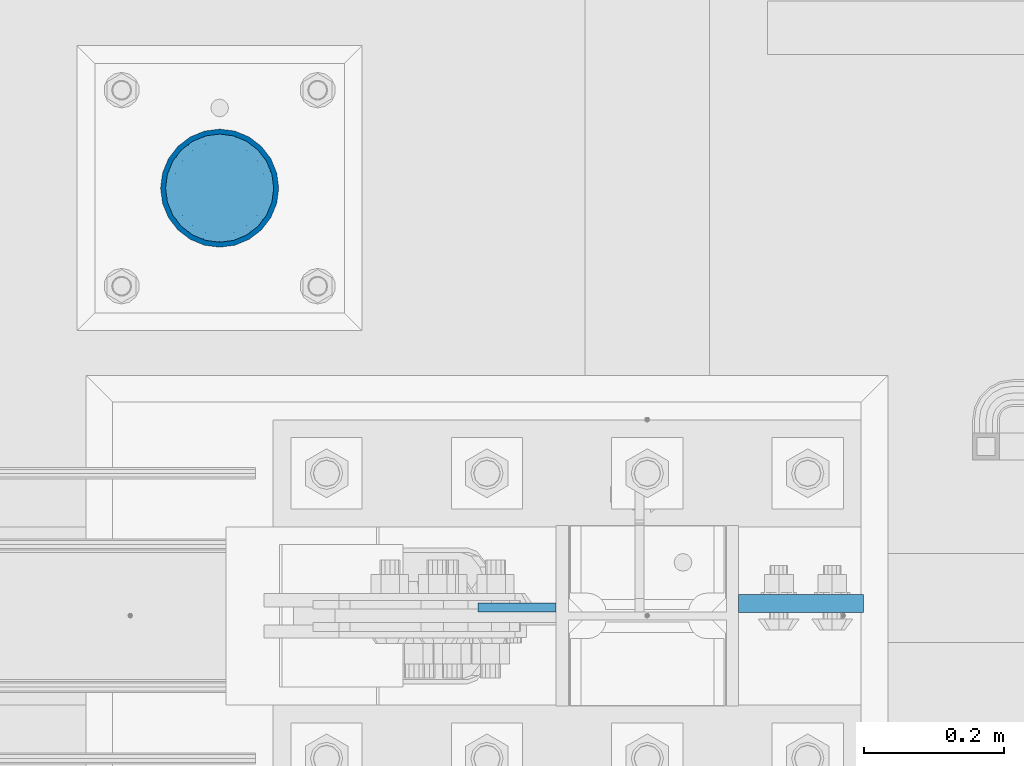
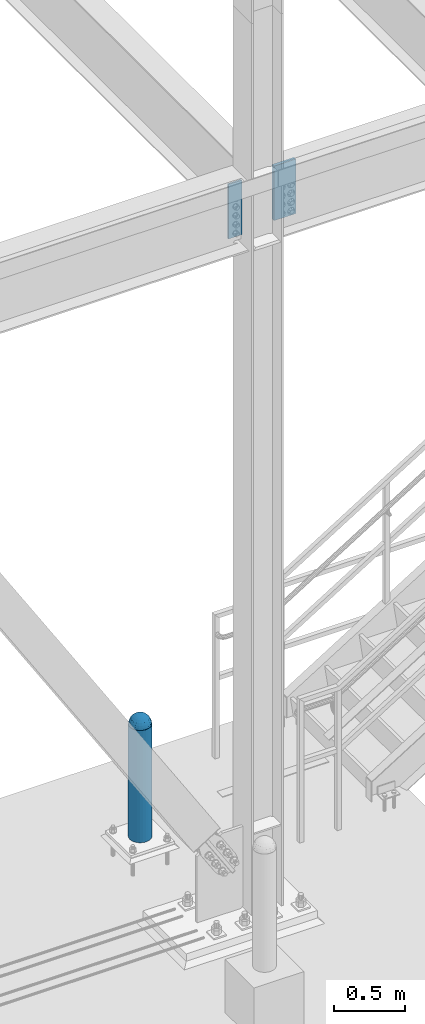
# One storey, part 1570 of 3843: 4 columns, 3 elements without a shape of their own.
"""IFC2X3 building model written with IfcOpenShell, lengths in millimetres."""

from ifc_helpers import new_model, si_unit, frame, origin_with_axes, place, context, subcontext, project, spatial, faceted_brep, material, type_object, element, aggregate, save


model = new_model("IFC2X3")

# Units and contexts
model_context = context("Model", 3, precision=1e-05, world=origin_with_axes())
body_context = subcontext(model_context, "Body", "Model", "MODEL_VIEW")
ifc_project = project(units=[si_unit("LENGTHUNIT", "METRE", prefix="MILLI"), si_unit("AREAUNIT", "SQUARE_METRE"), si_unit("VOLUMEUNIT", "CUBIC_METRE"), si_unit("MASSUNIT", "GRAM", prefix="KILO"), si_unit("TIMEUNIT", "SECOND"), si_unit("PLANEANGLEUNIT", "RADIAN"), si_unit("SOLIDANGLEUNIT", "STERADIAN"), si_unit("THERMODYNAMICTEMPERATUREUNIT", "DEGREE_CELSIUS"), si_unit("LUMINOUSINTENSITYUNIT", "LUMEN")], contexts=[model_context])

# Site, building, storey
site_placement = place(None, origin_with_axes())
site = spatial("IfcSite", under=ifc_project, at=site_placement, CompositionType="ELEMENT")
building_placement = place(site_placement, origin_with_axes())
building = spatial("IfcBuilding", under=site, at=building_placement, Name="Undefined", CompositionType="ELEMENT")
storey_placement = place(building_placement, origin_with_axes())
storey = spatial("IfcBuildingStorey", under=building, at=storey_placement, Name="Undefined", CompositionType="ELEMENT", Elevation=0.0)

# Assembly, column
assembly_1_placement = place(storey_placement, origin_with_axes())
assembly_1 = element("IfcElementAssembly", 1, at=assembly_1_placement, inside=storey, Name="CONC. FILL", AssemblyPlace="NOTDEFINED", PredefinedType="REINFORCEMENT_UNIT")
ifc_material_1 = material(Name="CONCRETE/1500")
column_type_1 = type_object("IfcColumnType", PredefinedType="NOTDEFINED")
column_1_placement = place(assembly_1_placement, frame((29870.4, 89725.5, 31411.8625), z_axis=(-1.0, 0.0, 0.0), x_axis=(0.0, 0.0, 1.0)))
column_1 = element("IfcColumn", 2, at=column_1_placement, type_object=column_type_1, material=ifc_material_1, Name="CONC. FILL", context=body_context, shape_type="Brep", body=[
    faceted_brep([(0.0, 0.0, 2.0), (0.0, -0.619999999995343, 1.89999999999964), (3.36549999999988, -7.1422259999963, 21.9814139999999), (3.36549999999988, 0.0, 23.1139999999996), (0.0, -1.17999999999302, 1.6200000000008), (3.36549999999988, -13.5910319999966, 18.6992260000006), (0.0, -1.61999999999534, 1.18000000000029), (3.36549999999988, -18.699225999997, 13.5910320000003), (0.0, -1.89999999999418, 0.6200000000008), (3.36549999999988, -21.9814139999944, 7.14222599999994), (0.0, -2.0, 0.0), (3.36549999999988, -23.1140000000014, 0.0), (0.0, -1.89999999999418, -0.6200000000008), (3.36549999999988, -21.9814139999944, -7.14222599999994), (0.0, -1.61999999999534, -1.18000000000029), (3.36549999999988, -18.699225999997, -13.5910320000003), (0.0, -1.17999999999302, -1.6200000000008), (3.36549999999988, -13.5910319999966, -18.6992260000006), (0.0, -0.619999999995343, -1.89999999999964), (3.36549999999988, -7.1422259999963, -21.9814139999999), (0.0, 0.0, -2.0), (3.36549999999988, 0.0, -23.1139999999996), (0.0, 0.619999999995343, -1.89999999999964), (3.36549999999988, 7.1422259999963, -21.9814139999999), (0.0, 1.17999999999302, -1.6200000000008), (3.36549999999988, 13.5910319999966, -18.6992260000006), (0.0, 1.61999999999534, -1.18000000000029), (3.36549999999988, 18.699225999997, -13.5910320000003), (0.0, 1.89999999999418, -0.6200000000008), (3.36549999999988, 21.9814139999944, -7.14222599999994), (0.0, 2.0, 0.0), (3.36549999999988, 23.1140000000014, 0.0), (0.0, 1.89999999999418, 0.6200000000008), (3.36549999999988, 21.9814139999944, 7.14222599999994), (0.0, 1.61999999999534, 1.18000000000029), (3.36549999999988, 18.699225999997, 13.5910320000003), (0.0, 1.17999999999302, 1.6200000000008), (3.36549999999988, 13.5910319999966, 18.6992260000006), (0.0, 0.619999999995343, 1.89999999999964), (3.36549999999988, 7.1422259999963, 21.9814139999999), (8.41374999999971, -11.1214661999984, 34.2282018000005), (8.41374999999971, 0.0, 35.9917999999998), (8.41374999999971, -21.1631784000056, 29.1173662000001), (8.41374999999971, -29.1173661999928, 21.1631784000001), (8.41374999999971, -34.2282017999969, 11.1214662000002), (8.41374999999971, -35.9918000000034, 0.0), (8.41374999999971, -34.2282017999969, -11.1214662000002), (8.41374999999971, -29.1173661999928, -21.1631784000001), (8.41374999999971, -21.1631784000056, -29.1173662000001), (8.41374999999971, -11.1214661999984, -34.2282018000005), (8.41374999999971, 0.0, -35.9917999999998), (8.41374999999971, 11.1214661999984, -34.2282018000005), (8.41374999999971, 21.1631784000056, -29.1173662000001), (8.41374999999971, 29.1173661999928, -21.1631784000001), (8.41374999999971, 34.2282017999969, -11.1214662000002), (8.41374999999971, 35.9918000000034, 0.0), (8.41374999999971, 34.2282017999969, 11.1214662000002), (8.41374999999971, 29.1173661999928, 21.1631784000001), (8.41374999999971, 21.1631784000056, 29.1173662000001), (8.41374999999971, 11.1214661999984, 34.2282018000005), (16.8274999999994, -15.3047700000025, 47.1030300000002), (16.8274999999994, 0.0, 49.5300000000007), (16.8274999999994, -29.1236400000053, 40.0697700000001), (16.8274999999994, -40.0697700000019, 29.1236399999998), (16.8274999999994, -47.1030299999984, 15.3047700000006), (16.8274999999994, -49.5299999999988, 0.0), (16.8274999999994, -47.1030299999984, -15.3047700000006), (16.8274999999994, -40.0697700000019, -29.1236399999998), (16.8274999999994, -29.1236400000053, -40.0697700000001), (16.8274999999994, -15.3047700000025, -47.1030300000002), (16.8274999999994, 0.0, -49.5300000000007), (16.8274999999994, 15.3047700000025, -47.1030300000002), (16.8274999999994, 29.1236400000053, -40.0697700000001), (16.8274999999994, 40.0697700000019, -29.1236399999998), (16.8274999999994, 47.1030299999984, -15.3047700000006), (16.8274999999994, 49.5299999999988, 0.0), (16.8274999999994, 47.1030299999984, 15.3047700000006), (16.8274999999994, 40.0697700000019, 29.1236399999998), (16.8274999999994, 29.1236400000053, 40.0697700000001), (16.8274999999994, 15.3047700000025, 47.1030300000002), (33.6549999999988, -20.4063599999936, 62.8040400000009), (33.6549999999988, 0.0, 66.0400000000009), (33.6549999999988, -38.831520000007, 53.4263599999995), (33.6549999999988, -53.4263599999977, 38.8315199999997), (33.6549999999988, -62.8040400000027, 20.4063600000009), (33.6549999999988, -66.0399999999936, 0.0), (33.6549999999988, -62.8040400000027, -20.4063600000009), (33.6549999999988, -53.4263599999977, -38.8315199999997), (33.6549999999988, -38.831520000007, -53.4263599999995), (33.6549999999988, -20.4063599999936, -62.8040400000009), (33.6549999999988, 0.0, -66.0400000000009), (33.6549999999988, 20.4063599999936, -62.8040400000009), (33.6549999999988, 38.831520000007, -53.4263599999995), (33.6549999999988, 53.4263599999977, -38.8315199999997), (33.6549999999988, 62.8040400000027, -20.4063600000009), (33.6549999999988, 66.0399999999936, 0.0), (33.6549999999988, 62.8040400000027, 20.4063600000009), (33.6549999999988, 53.4263599999977, 38.8315199999997), (33.6549999999988, 38.831520000007, 53.4263599999995), (33.6549999999988, 20.4063599999936, 62.8040400000009), (50.4824999999983, -23.3907901500061, 71.9891308499991), (50.4824999999983, 0.0, 75.6983500000006), (50.4824999999983, -44.5106298000028, 61.23996515), (50.4824999999983, -61.2399651500018, 44.5106297999992), (50.4824999999983, -71.9891308499937, 23.3907901500006), (50.4824999999983, -75.698350000006, 0.0), (50.4824999999983, -71.9891308499937, -23.3907901500006), (50.4824999999983, -61.2399651500018, -44.5106297999992), (50.4824999999983, -44.5106298000028, -61.23996515), (50.4824999999983, -23.3907901500061, -71.9891308499991), (50.4824999999983, 0.0, -75.6983500000006), (50.4824999999983, 23.3907901500061, -71.9891308499991), (50.4824999999983, 44.5106298000028, -61.23996515), (50.4824999999983, 61.2399651500018, -44.5106297999992), (50.4824999999983, 71.9891308499937, -23.3907901500006), (50.4824999999983, 75.698350000006, 0.0), (50.4824999999983, 71.9891308499937, 23.3907901500006), (50.4824999999983, 61.2399651500018, 44.5106297999992), (50.4824999999983, 44.5106298000028, 61.23996515), (50.4824999999983, 23.3907901500061, 71.9891308499991), (67.3099999999977, -24.9977910000016, 76.9349490000004), (67.3099999999977, 0.0, 80.8989999999994), (67.3099999999977, -47.5686120000028, 65.4472910000004), (67.3099999999977, -65.447291000004, 47.5686119999991), (67.3099999999977, -76.9349490000022, 24.9977909999998), (67.3099999999977, -80.8990000000049, 0.0), (67.3099999999977, -76.9349490000022, -24.9977909999998), (67.3099999999977, -65.447291000004, -47.5686119999991), (67.3099999999977, -47.5686120000028, -65.4472910000004), (67.3099999999977, -24.9977910000016, -76.9349490000004), (67.3099999999977, 0.0, -80.8989999999994), (67.3099999999977, 24.9977910000016, -76.9349490000004), (67.3099999999977, 47.5686120000028, -65.4472910000004), (67.3099999999977, 65.447291000004, -47.5686119999991), (67.3099999999977, 76.9349490000022, -24.9977909999998), (67.3099999999977, 80.8990000000049, 0.0), (67.3099999999977, 76.9349490000022, 24.9977909999998), (67.3099999999977, 65.447291000004, 47.5686119999991), (67.3099999999977, 47.5686120000028, 65.4472910000004), (67.3099999999977, 24.9977910000016, 76.9349490000004), (84.1374999999935, -25.5079499999993, 78.5050499999998), (84.1374999999935, 0.0, 82.5499999999993), (84.1374999999935, -48.5393999999942, 66.7829500000007), (84.1374999999935, -66.7829499999934, 48.5393999999997), (84.1374999999935, -78.505050000007, 25.5079499999993), (84.1374999999935, -82.5500000000029, 0.0), (84.1374999999935, -78.505050000007, -25.5079499999993), (84.1374999999935, -66.7829499999934, -48.5393999999997), (84.1374999999935, -48.5393999999942, -66.7829500000007), (84.1374999999935, -25.5079499999993, -78.5050499999998), (84.1374999999935, 0.0, -82.5499999999993), (84.1374999999935, 25.5079499999993, -78.5050499999998), (84.1374999999935, 48.5393999999942, -66.7829500000007), (84.1374999999935, 66.7829499999934, -48.5393999999997), (84.1374999999935, 78.505050000007, -25.5079499999993), (84.1374999999935, 82.5500000000029, 0.0), (84.1374999999935, 78.505050000007, 25.5079499999993), (84.1374999999935, 66.7829499999934, 48.5393999999997), (84.1374999999935, 48.5393999999942, 66.7829500000007), (84.1374999999935, 25.5079499999993, 78.5050499999998), (100.964999999993, -24.9977910000016, 76.9349490000004), (100.964999999993, 0.0, 80.8989999999994), (100.964999999993, -47.5686120000028, 65.4472910000004), (100.964999999993, -65.447291000004, 47.5686119999991), (100.964999999993, -76.9349490000022, 24.9977909999998), (100.964999999993, -80.8990000000049, 0.0), (100.964999999993, -76.9349490000022, -24.9977909999998), (100.964999999993, -65.447291000004, -47.5686119999991), (100.964999999993, -47.5686120000028, -65.4472910000004), (100.964999999993, -24.9977910000016, -76.9349490000004), (100.964999999993, 0.0, -80.8989999999994), (100.964999999993, 24.9977910000016, -76.9349490000004), (100.964999999993, 47.5686120000028, -65.4472910000004), (100.964999999993, 65.447291000004, -47.5686119999991), (100.964999999993, 76.9349490000022, -24.9977909999998), (100.964999999993, 80.8990000000049, 0.0), (100.964999999993, 76.9349490000022, 24.9977909999998), (100.964999999993, 65.447291000004, 47.5686119999991), (100.964999999993, 47.5686120000028, 65.4472910000004), (100.964999999993, 24.9977910000016, 76.9349490000004), (117.792499999992, -23.3907901500061, 71.9891308499991), (117.792499999992, 0.0, 75.6983500000006), (117.792499999992, -44.5106298000028, 61.23996515), (117.792499999992, -61.2399651500018, 44.5106297999992), (117.792499999992, -71.9891308499937, 23.3907901500006), (117.792499999992, -75.698350000006, 0.0), (117.792499999992, -71.9891308499937, -23.3907901500006), (117.792499999992, -61.2399651500018, -44.5106297999992), (117.792499999992, -44.5106298000028, -61.23996515), (117.792499999992, -23.3907901500061, -71.9891308499991), (117.792499999992, 0.0, -75.6983500000006), (117.792499999992, 23.3907901500061, -71.9891308499991), (117.792499999992, 44.5106298000028, -61.23996515), (117.792499999992, 61.2399651500018, -44.5106297999992), (117.792499999992, 71.9891308499937, -23.3907901500006), (117.792499999992, 75.698350000006, 0.0), (117.792499999992, 71.9891308499937, 23.3907901500006), (117.792499999992, 61.2399651500018, 44.5106297999992), (117.792499999992, 44.5106298000028, 61.23996515), (117.792499999992, 23.3907901500061, 71.9891308499991), (134.619999999992, -20.4063599999936, 62.8040400000009), (134.619999999992, 0.0, 66.0400000000009), (134.619999999992, -38.831520000007, 53.4263599999995), (134.619999999992, -53.4263599999977, 38.8315199999997), (134.619999999992, -62.8040400000027, 20.4063600000009), (134.619999999992, -66.0399999999936, 0.0), (134.619999999992, -62.8040400000027, -20.4063600000009), (134.619999999992, -53.4263599999977, -38.8315199999997), (134.619999999992, -38.831520000007, -53.4263599999995), (134.619999999992, -20.4063599999936, -62.8040400000009), (134.619999999992, 0.0, -66.0400000000009), (134.619999999992, 20.4063599999936, -62.8040400000009), (134.619999999992, 38.831520000007, -53.4263599999995), (134.619999999992, 53.4263599999977, -38.8315199999997), (134.619999999992, 62.8040400000027, -20.4063600000009), (134.619999999992, 66.0399999999936, 0.0), (134.619999999992, 62.8040400000027, 20.4063600000009), (134.619999999992, 53.4263599999977, 38.8315199999997), (134.619999999992, 38.831520000007, 53.4263599999995), (134.619999999992, 20.4063599999936, 62.8040400000009), (151.447499999991, -15.3047700000025, 47.1030300000002), (151.447499999991, 0.0, 49.5300000000007), (151.447499999991, -29.1236400000053, 40.0697700000001), (151.447499999991, -40.0697700000019, 29.1236399999998), (151.447499999991, -47.1030299999984, 15.3047700000006), (151.447499999991, -49.5299999999988, 0.0), (151.447499999991, -47.1030299999984, -15.3047700000006), (151.447499999991, -40.0697700000019, -29.1236399999998), (151.447499999991, -29.1236400000053, -40.0697700000001), (151.447499999991, -15.3047700000025, -47.1030300000002), (151.447499999991, 0.0, -49.5300000000007), (151.447499999991, 15.3047700000025, -47.1030300000002), (151.447499999991, 29.1236400000053, -40.0697700000001), (151.447499999991, 40.0697700000019, -29.1236399999998), (151.447499999991, 47.1030299999984, -15.3047700000006), (151.447499999991, 49.5299999999988, 0.0), (151.447499999991, 47.1030299999984, 15.3047700000006), (151.447499999991, 40.0697700000019, 29.1236399999998), (151.447499999991, 29.1236400000053, 40.0697700000001), (151.447499999991, 15.3047700000025, 47.1030300000002), (159.861249999991, -11.1214661999984, 34.2282018000005), (159.861249999991, 0.0, 35.9917999999998), (159.861249999991, -21.1631784000056, 29.1173662000001), (159.861249999991, -29.1173661999928, 21.1631784000001), (159.861249999991, -34.2282017999969, 11.1214662000002), (159.861249999991, -35.9918000000034, 0.0), (159.861249999991, -34.2282017999969, -11.1214662000002), (159.861249999991, -29.1173661999928, -21.1631784000001), (159.861249999991, -21.1631784000056, -29.1173662000001), (159.861249999991, -11.1214661999984, -34.2282018000005), (159.861249999991, 0.0, -35.9917999999998), (159.861249999991, 11.1214661999984, -34.2282018000005), (159.861249999991, 21.1631784000056, -29.1173662000001), (159.861249999991, 29.1173661999928, -21.1631784000001), (159.861249999991, 34.2282017999969, -11.1214662000002), (159.861249999991, 35.9918000000034, 0.0), (159.861249999991, 34.2282017999969, 11.1214662000002), (159.861249999991, 29.1173661999928, 21.1631784000001), (159.861249999991, 21.1631784000056, 29.1173662000001), (159.861249999991, 11.1214661999984, 34.2282018000005), (164.909499999991, -7.1422259999963, 21.9814139999999), (164.909499999991, 0.0, 23.1139999999996), (164.909499999991, -13.5910319999966, 18.6992260000006), (164.909499999991, -18.699225999997, 13.5910320000003), (164.909499999991, -21.9814139999944, 7.14222599999994), (164.909499999991, -23.1140000000014, 0.0), (164.909499999991, -21.9814139999944, -7.14222599999994), (164.909499999991, -18.699225999997, -13.5910320000003), (164.909499999991, -13.5910319999966, -18.6992260000006), (164.909499999991, -7.1422259999963, -21.9814139999999), (164.909499999991, 0.0, -23.1139999999996), (164.909499999991, 7.1422259999963, -21.9814139999999), (164.909499999991, 13.5910319999966, -18.6992260000006), (164.909499999991, 18.699225999997, -13.5910320000003), (164.909499999991, 21.9814139999944, -7.14222599999994), (164.909499999991, 23.1140000000014, 0.0), (164.909499999991, 21.9814139999944, 7.14222599999994), (164.909499999991, 18.699225999997, 13.5910320000003), (164.909499999991, 13.5910319999966, 18.6992260000006), (164.909499999991, 7.1422259999963, 21.9814139999999), (168.274999999991, -0.619999999995343, 1.89999999999964), (168.274999999991, 0.0, 2.0), (168.274999999991, -1.17999999999302, 1.6200000000008), (168.274999999991, -1.61999999999534, 1.18000000000029), (168.274999999991, -1.89999999999418, 0.6200000000008), (168.274999999991, -2.0, 0.0), (168.274999999991, -1.89999999999418, -0.6200000000008), (168.274999999991, -1.61999999999534, -1.18000000000029), (168.274999999991, -1.17999999999302, -1.6200000000008), (168.274999999991, -0.619999999995343, -1.89999999999964), (168.274999999991, 0.0, -2.0), (168.274999999991, 0.619999999995343, -1.89999999999964), (168.274999999991, 1.17999999999302, -1.6200000000008), (168.274999999991, 1.61999999999534, -1.18000000000029), (168.274999999991, 1.89999999999418, -0.6200000000008), (168.274999999991, 2.0, 0.0), (168.274999999991, 1.89999999999418, 0.6200000000008), (168.274999999991, 1.61999999999534, 1.18000000000029), (168.274999999991, 1.17999999999302, 1.6200000000008), (168.274999999991, 0.619999999995343, 1.89999999999964)], [[[0, 1, 2, 3]], [[1, 4, 5, 2]], [[4, 6, 7, 5]], [[6, 8, 9, 7]], [[8, 10, 11, 9]], [[10, 12, 13, 11]], [[12, 14, 15, 13]], [[14, 16, 17, 15]], [[16, 18, 19, 17]], [[18, 20, 21, 19]], [[20, 22, 23, 21]], [[22, 24, 25, 23]], [[24, 26, 27, 25]], [[26, 28, 29, 27]], [[28, 30, 31, 29]], [[30, 32, 33, 31]], [[32, 34, 35, 33]], [[34, 36, 37, 35]], [[36, 38, 39, 37]], [[38, 0, 3, 39]], [[38, 36, 34, 32, 30, 28, 26, 24, 22, 20, 18, 16, 14, 12, 10, 8, 6, 4, 1, 0]], [[3, 2, 40, 41]], [[2, 5, 42, 40]], [[5, 7, 43, 42]], [[7, 9, 44, 43]], [[9, 11, 45, 44]], [[11, 13, 46, 45]], [[13, 15, 47, 46]], [[15, 17, 48, 47]], [[17, 19, 49, 48]], [[19, 21, 50, 49]], [[21, 23, 51, 50]], [[23, 25, 52, 51]], [[25, 27, 53, 52]], [[27, 29, 54, 53]], [[29, 31, 55, 54]], [[31, 33, 56, 55]], [[33, 35, 57, 56]], [[35, 37, 58, 57]], [[37, 39, 59, 58]], [[39, 3, 41, 59]], [[41, 40, 60, 61]], [[40, 42, 62, 60]], [[42, 43, 63, 62]], [[43, 44, 64, 63]], [[44, 45, 65, 64]], [[45, 46, 66, 65]], [[46, 47, 67, 66]], [[47, 48, 68, 67]], [[48, 49, 69, 68]], [[49, 50, 70, 69]], [[50, 51, 71, 70]], [[51, 52, 72, 71]], [[52, 53, 73, 72]], [[53, 54, 74, 73]], [[54, 55, 75, 74]], [[55, 56, 76, 75]], [[56, 57, 77, 76]], [[57, 58, 78, 77]], [[58, 59, 79, 78]], [[59, 41, 61, 79]], [[61, 60, 80, 81]], [[60, 62, 82, 80]], [[62, 63, 83, 82]], [[63, 64, 84, 83]], [[64, 65, 85, 84]], [[65, 66, 86, 85]], [[66, 67, 87, 86]], [[67, 68, 88, 87]], [[68, 69, 89, 88]], [[69, 70, 90, 89]], [[70, 71, 91, 90]], [[71, 72, 92, 91]], [[72, 73, 93, 92]], [[73, 74, 94, 93]], [[74, 75, 95, 94]], [[75, 76, 96, 95]], [[76, 77, 97, 96]], [[77, 78, 98, 97]], [[78, 79, 99, 98]], [[79, 61, 81, 99]], [[81, 80, 100, 101]], [[80, 82, 102, 100]], [[82, 83, 103, 102]], [[83, 84, 104, 103]], [[84, 85, 105, 104]], [[85, 86, 106, 105]], [[86, 87, 107, 106]], [[87, 88, 108, 107]], [[88, 89, 109, 108]], [[89, 90, 110, 109]], [[90, 91, 111, 110]], [[91, 92, 112, 111]], [[92, 93, 113, 112]], [[93, 94, 114, 113]], [[94, 95, 115, 114]], [[95, 96, 116, 115]], [[96, 97, 117, 116]], [[97, 98, 118, 117]], [[98, 99, 119, 118]], [[99, 81, 101, 119]], [[101, 100, 120, 121]], [[100, 102, 122, 120]], [[102, 103, 123, 122]], [[103, 104, 124, 123]], [[104, 105, 125, 124]], [[105, 106, 126, 125]], [[106, 107, 127, 126]], [[107, 108, 128, 127]], [[108, 109, 129, 128]], [[109, 110, 130, 129]], [[110, 111, 131, 130]], [[111, 112, 132, 131]], [[112, 113, 133, 132]], [[113, 114, 134, 133]], [[114, 115, 135, 134]], [[115, 116, 136, 135]], [[116, 117, 137, 136]], [[117, 118, 138, 137]], [[118, 119, 139, 138]], [[119, 101, 121, 139]], [[121, 120, 140, 141]], [[120, 122, 142, 140]], [[122, 123, 143, 142]], [[123, 124, 144, 143]], [[124, 125, 145, 144]], [[125, 126, 146, 145]], [[126, 127, 147, 146]], [[127, 128, 148, 147]], [[128, 129, 149, 148]], [[129, 130, 150, 149]], [[130, 131, 151, 150]], [[131, 132, 152, 151]], [[132, 133, 153, 152]], [[133, 134, 154, 153]], [[134, 135, 155, 154]], [[135, 136, 156, 155]], [[136, 137, 157, 156]], [[137, 138, 158, 157]], [[138, 139, 159, 158]], [[139, 121, 141, 159]], [[141, 140, 160, 161]], [[140, 142, 162, 160]], [[142, 143, 163, 162]], [[143, 144, 164, 163]], [[144, 145, 165, 164]], [[145, 146, 166, 165]], [[146, 147, 167, 166]], [[147, 148, 168, 167]], [[148, 149, 169, 168]], [[149, 150, 170, 169]], [[150, 151, 171, 170]], [[151, 152, 172, 171]], [[152, 153, 173, 172]], [[153, 154, 174, 173]], [[154, 155, 175, 174]], [[155, 156, 176, 175]], [[156, 157, 177, 176]], [[157, 158, 178, 177]], [[158, 159, 179, 178]], [[159, 141, 161, 179]], [[161, 160, 180, 181]], [[160, 162, 182, 180]], [[162, 163, 183, 182]], [[163, 164, 184, 183]], [[164, 165, 185, 184]], [[165, 166, 186, 185]], [[166, 167, 187, 186]], [[167, 168, 188, 187]], [[168, 169, 189, 188]], [[169, 170, 190, 189]], [[170, 171, 191, 190]], [[171, 172, 192, 191]], [[172, 173, 193, 192]], [[173, 174, 194, 193]], [[174, 175, 195, 194]], [[175, 176, 196, 195]], [[176, 177, 197, 196]], [[177, 178, 198, 197]], [[178, 179, 199, 198]], [[179, 161, 181, 199]], [[181, 180, 200, 201]], [[180, 182, 202, 200]], [[182, 183, 203, 202]], [[183, 184, 204, 203]], [[184, 185, 205, 204]], [[185, 186, 206, 205]], [[186, 187, 207, 206]], [[187, 188, 208, 207]], [[188, 189, 209, 208]], [[189, 190, 210, 209]], [[190, 191, 211, 210]], [[191, 192, 212, 211]], [[192, 193, 213, 212]], [[193, 194, 214, 213]], [[194, 195, 215, 214]], [[195, 196, 216, 215]], [[196, 197, 217, 216]], [[197, 198, 218, 217]], [[198, 199, 219, 218]], [[199, 181, 201, 219]], [[201, 200, 220, 221]], [[200, 202, 222, 220]], [[202, 203, 223, 222]], [[203, 204, 224, 223]], [[204, 205, 225, 224]], [[205, 206, 226, 225]], [[206, 207, 227, 226]], [[207, 208, 228, 227]], [[208, 209, 229, 228]], [[209, 210, 230, 229]], [[210, 211, 231, 230]], [[211, 212, 232, 231]], [[212, 213, 233, 232]], [[213, 214, 234, 233]], [[214, 215, 235, 234]], [[215, 216, 236, 235]], [[216, 217, 237, 236]], [[217, 218, 238, 237]], [[218, 219, 239, 238]], [[219, 201, 221, 239]], [[221, 220, 240, 241]], [[220, 222, 242, 240]], [[222, 223, 243, 242]], [[223, 224, 244, 243]], [[224, 225, 245, 244]], [[225, 226, 246, 245]], [[226, 227, 247, 246]], [[227, 228, 248, 247]], [[228, 229, 249, 248]], [[229, 230, 250, 249]], [[230, 231, 251, 250]], [[231, 232, 252, 251]], [[232, 233, 253, 252]], [[233, 234, 254, 253]], [[234, 235, 255, 254]], [[235, 236, 256, 255]], [[236, 237, 257, 256]], [[237, 238, 258, 257]], [[238, 239, 259, 258]], [[239, 221, 241, 259]], [[241, 240, 260, 261]], [[240, 242, 262, 260]], [[242, 243, 263, 262]], [[243, 244, 264, 263]], [[244, 245, 265, 264]], [[245, 246, 266, 265]], [[246, 247, 267, 266]], [[247, 248, 268, 267]], [[248, 249, 269, 268]], [[249, 250, 270, 269]], [[250, 251, 271, 270]], [[251, 252, 272, 271]], [[252, 253, 273, 272]], [[253, 254, 274, 273]], [[254, 255, 275, 274]], [[255, 256, 276, 275]], [[256, 257, 277, 276]], [[257, 258, 278, 277]], [[258, 259, 279, 278]], [[259, 241, 261, 279]], [[261, 260, 280, 281]], [[260, 262, 282, 280]], [[262, 263, 283, 282]], [[263, 264, 284, 283]], [[264, 265, 285, 284]], [[265, 266, 286, 285]], [[266, 267, 287, 286]], [[267, 268, 288, 287]], [[268, 269, 289, 288]], [[269, 270, 290, 289]], [[270, 271, 291, 290]], [[271, 272, 292, 291]], [[272, 273, 293, 292]], [[273, 274, 294, 293]], [[274, 275, 295, 294]], [[275, 276, 296, 295]], [[276, 277, 297, 296]], [[277, 278, 298, 297]], [[278, 279, 299, 298]], [[279, 261, 281, 299]], [[282, 283, 284, 285, 286, 287, 288, 289, 290, 291, 292, 293, 294, 295, 296, 297, 298, 299, 281, 280]]]),
])
aggregate(assembly_1, [column_1])

assembly_2_placement = place(storey_placement, origin_with_axes())
assembly_2 = element("IfcElementAssembly", 3, at=assembly_2_placement, inside=storey, Name="PIPE_BOLLARD", AssemblyPlace="NOTDEFINED", PredefinedType="RIGID_FRAME")
ifc_material_2 = material()
column_type_2 = type_object("IfcColumnType", Name="PIPE6SCH40", PredefinedType="NOTDEFINED")
column_2_placement = place(assembly_2_placement, frame((29870.4, 89725.5, 30480.0), z_axis=(-1.0, 0.0, 0.0), x_axis=(0.0, 0.0, 1.0)))
column_2 = element("IfcColumn", 4, at=column_2_placement, type_object=column_type_2, material=ifc_material_2, Name="PIPE_BOLLARD", ObjectType="PIPE6SCH40", context=body_context, shape_type="Brep", body=[
    faceted_brep([(50.7999999999993, -77.0890000000072, 0.0), (50.7999999999993, -74.4622560228017, 19.9521013679114), (1016.0, -74.4622560228017, 19.9521013679114), (1016.0, -77.0890000000072, 0.0), (50.7999999999993, -66.7610323523404, 38.5445000000036), (1016.0, -66.7610323523404, 38.5445000000036), (50.7999999999993, -54.5101546548831, 54.5101546548904), (1016.0, -54.5101546548831, 54.5101546548904), (50.7999999999993, -38.5445000000036, 66.7610323523404), (1016.0, -38.5445000000036, 66.7610323523404), (50.7999999999993, -19.9521013679041, 74.4622560227945), (1016.0, -19.9521013679041, 74.4622560227945), (50.7999999999993, 0.0, 77.0889999999999), (1016.0, 0.0, 77.0889999999999), (50.7999999999993, 19.9521013679041, 74.4622560227945), (1016.0, 19.9521013679041, 74.4622560227945), (50.7999999999993, 38.5445000000036, 66.7610323523404), (1016.0, 38.5445000000036, 66.7610323523404), (50.7999999999993, 54.5101546548831, 54.5101546548904), (1016.0, 54.5101546548831, 54.5101546548904), (50.7999999999993, 66.7610323523404, 38.5445000000036), (1016.0, 66.7610323523404, 38.5445000000036), (50.7999999999993, 74.4622560228017, 19.9521013679114), (1016.0, 74.4622560228017, 19.9521013679114), (50.7999999999993, 77.0890000000072, 0.0), (1016.0, 77.0890000000072, 0.0), (50.7999999999993, 74.4622560228017, -19.9521013679114), (1016.0, 74.4622560228017, -19.9521013679114), (50.7999999999993, 66.7610323523404, -38.5445000000036), (1016.0, 66.7610323523404, -38.5445000000036), (50.7999999999993, 54.5101546548831, -54.5101546548904), (1016.0, 54.5101546548831, -54.5101546548904), (50.7999999999993, 38.5445000000036, -66.7610323523404), (1016.0, 38.5445000000036, -66.7610323523404), (50.7999999999993, 19.9521013679041, -74.4622560227945), (1016.0, 19.9521013679041, -74.4622560227945), (50.7999999999993, 0.0, -77.0889999999999), (1016.0, 0.0, -77.0889999999999), (50.7999999999993, -19.9521013679041, -74.4622560227945), (1016.0, -19.9521013679041, -74.4622560227945), (50.7999999999993, -38.5445000000036, -66.7610323523404), (1016.0, -38.5445000000036, -66.7610323523404), (50.7999999999993, -54.5101546548831, -54.5101546548904), (1016.0, -54.5101546548831, -54.5101546548904), (50.7999999999993, -66.7610323523404, -38.5445000000036), (1016.0, -66.7610323523404, -38.5445000000036), (50.7999999999993, -74.4622560228017, -19.9521013679114), (1016.0, -74.4622560228017, -19.9521013679114), (50.7999999999993, -84.2010000000009, 0.0), (50.7999999999993, -81.3319204993604, -21.7928224166753), (1016.0, -81.3319204993604, -21.7928224166753), (1016.0, -84.2010000000009, 0.0), (50.7999999999993, -72.9202050240565, -42.1005000000005), (1016.0, -72.9202050240565, -42.1005000000005), (50.7999999999993, -59.5390980826924, -59.5390980826851), (1016.0, -59.5390980826924, -59.5390980826851), (50.7999999999993, -42.1005000000005, -72.9202050240565), (1016.0, -42.1005000000005, -72.9202050240565), (50.7999999999993, -21.7928224166826, -81.3319204993677), (1016.0, -21.7928224166826, -81.3319204993677), (50.7999999999993, 0.0, -84.2010000000009), (1016.0, 0.0, -84.2010000000009), (50.7999999999993, 21.7928224166826, -81.3319204993677), (1016.0, 21.7928224166826, -81.3319204993677), (50.7999999999993, 42.1005000000005, -72.9202050240565), (1016.0, 42.1005000000005, -72.9202050240565), (50.7999999999993, 59.5390980826924, -59.5390980826851), (1016.0, 59.5390980826924, -59.5390980826851), (50.7999999999993, 72.9202050240565, -42.1005000000005), (1016.0, 72.9202050240565, -42.1005000000005), (50.7999999999993, 81.3319204993604, -21.7928224166753), (1016.0, 81.3319204993604, -21.7928224166753), (50.7999999999993, 84.2010000000009, 0.0), (1016.0, 84.2010000000009, 0.0), (50.7999999999993, 81.3319204993604, 21.7928224166753), (1016.0, 81.3319204993604, 21.7928224166753), (50.7999999999993, 72.9202050240565, 42.1005000000005), (1016.0, 72.9202050240565, 42.1005000000005), (50.7999999999993, 59.5390980826924, 59.5390980826851), (1016.0, 59.5390980826924, 59.5390980826851), (50.7999999999993, 42.1005000000005, 72.9202050240565), (1016.0, 42.1005000000005, 72.9202050240565), (50.7999999999993, 21.7928224166826, 81.3319204993677), (1016.0, 21.7928224166826, 81.3319204993677), (50.7999999999993, 0.0, 84.2010000000009), (1016.0, 0.0, 84.2010000000009), (50.7999999999993, -21.7928224166826, 81.3319204993677), (1016.0, -21.7928224166826, 81.3319204993677), (50.7999999999993, -42.1005000000005, 72.9202050240565), (1016.0, -42.1005000000005, 72.9202050240565), (50.7999999999993, -59.5390980826924, 59.5390980826851), (1016.0, -59.5390980826924, 59.5390980826851), (50.7999999999993, -72.9202050240565, 42.1005000000005), (1016.0, -72.9202050240565, 42.1005000000005), (50.7999999999993, -81.3319204993604, 21.7928224166753), (1016.0, -81.3319204993604, 21.7928224166753)], [[[0, 1, 2, 3]], [[1, 4, 5, 2]], [[4, 6, 7, 5]], [[6, 8, 9, 7]], [[8, 10, 11, 9]], [[10, 12, 13, 11]], [[12, 14, 15, 13]], [[14, 16, 17, 15]], [[16, 18, 19, 17]], [[18, 20, 21, 19]], [[20, 22, 23, 21]], [[22, 24, 25, 23]], [[24, 26, 27, 25]], [[26, 28, 29, 27]], [[28, 30, 31, 29]], [[30, 32, 33, 31]], [[32, 34, 35, 33]], [[34, 36, 37, 35]], [[36, 38, 39, 37]], [[38, 40, 41, 39]], [[40, 42, 43, 41]], [[42, 44, 45, 43]], [[44, 46, 47, 45]], [[46, 0, 3, 47]], [[48, 49, 50, 51]], [[49, 52, 53, 50]], [[52, 54, 55, 53]], [[54, 56, 57, 55]], [[56, 58, 59, 57]], [[58, 60, 61, 59]], [[60, 62, 63, 61]], [[62, 64, 65, 63]], [[64, 66, 67, 65]], [[66, 68, 69, 67]], [[68, 70, 71, 69]], [[70, 72, 73, 71]], [[72, 74, 75, 73]], [[74, 76, 77, 75]], [[76, 78, 79, 77]], [[78, 80, 81, 79]], [[80, 82, 83, 81]], [[82, 84, 85, 83]], [[84, 86, 87, 85]], [[86, 88, 89, 87]], [[88, 90, 91, 89]], [[90, 92, 93, 91]], [[92, 94, 95, 93]], [[94, 48, 51, 95]], [[53, 55, 57, 59, 61, 63, 65, 67, 69, 71, 73, 75, 77, 79, 81, 83, 85, 87, 89, 91, 93, 95, 51, 50], [5, 7, 9, 11, 13, 15, 17, 19, 21, 23, 25, 27, 29, 31, 33, 35, 37, 39, 41, 43, 45, 47, 3, 2]], [[94, 92, 90, 88, 86, 84, 82, 80, 78, 76, 74, 72, 70, 68, 66, 64, 62, 60, 58, 56, 54, 52, 49, 48], [46, 44, 42, 40, 38, 36, 34, 32, 30, 28, 26, 24, 22, 20, 18, 16, 14, 12, 10, 8, 6, 4, 1, 0]]]),
])
aggregate(assembly_2, [column_2])

# Assembly, columns
assembly_3_placement = place(storey_placement, origin_with_axes())
assembly_3 = element("IfcElementAssembly", 5, at=assembly_3_placement, inside=storey, Name="COLUMN", AssemblyPlace="NOTDEFINED", PredefinedType="RIGID_FRAME")
ifc_material_3 = material(Name="STEEL/A572-50")
column_type_3 = type_object("IfcColumnType", PredefinedType="NOTDEFINED")
column_3_placement = place(assembly_3_placement, frame((30294.2625, 89127.8060002327, 35899.725), z_axis=(1.0, 0.0, 0.0), x_axis=(0.0, 0.0, 1.0)))
column_3 = element("IfcColumn", 6, at=column_3_placement, type_object=column_type_3, material=ifc_material_3, Name="PLATE", context=body_context, shape_type="Brep", body=[
    faceted_brep([(0.0, 6.35000000000582, -55.5625), (0.0, 6.35000000000582, 55.5625), (469.899999999994, 6.35000000000582, 55.5625), (469.899999999994, 6.35000000000582, -55.5625), (0.0, -6.35000000000582, 55.5625), (469.899999999994, -6.35000000000582, 55.5625), (0.0, -6.35000000000582, -55.5625), (469.899999999994, -6.35000000000582, -55.5625)], [[[0, 1, 2, 3]], [[1, 4, 5, 2]], [[4, 6, 7, 5]], [[6, 0, 3, 7]], [[5, 7, 3, 2]], [[6, 4, 1, 0]]]),
])
column_type_4 = type_object("IfcColumnType", PredefinedType="NOTDEFINED")
column_4_placement = place(assembly_3_placement, frame((30699.075, 89133.3620000839, 35928.3), z_axis=(-1.0, 0.0, 0.0), x_axis=(0.0, 0.0, 1.0)))
column_4 = element("IfcColumn", 7, at=column_4_placement, type_object=column_type_4, material=ifc_material_3, Name="PLATE", context=body_context, shape_type="Brep", body=[
    faceted_brep([(0.0, 12.6999999999971, -88.9000000000015), (0.0, 12.7000000000007, 88.9000015258789), (469.900000000001, 12.6999999999971, 88.9000000000015), (469.900000000001, 12.6999999999971, -88.9000000000015), (0.0, -12.7000000000007, 88.9000015258789), (469.900000000001, -12.6999999999971, 88.9000000000015), (0.0, -12.6999999999971, -88.9000000000015), (469.900000000001, -12.6999999999971, -88.9000000000015)], [[[0, 1, 2, 3]], [[1, 4, 5, 2]], [[4, 6, 7, 5]], [[6, 0, 3, 7]], [[5, 7, 3, 2]], [[6, 4, 1, 0]]]),
])
aggregate(assembly_3, [column_4, column_3])

save(model, "model.ifc")
